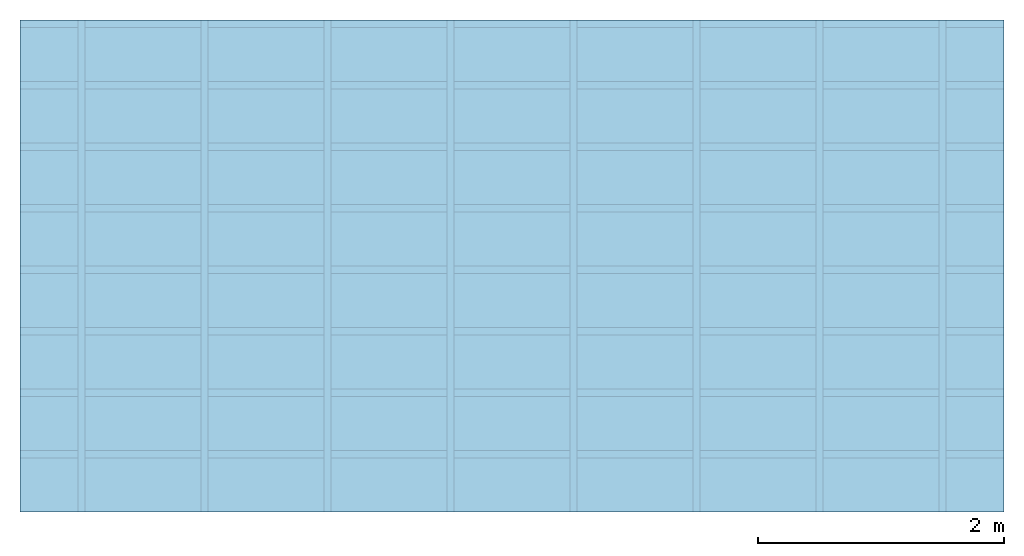
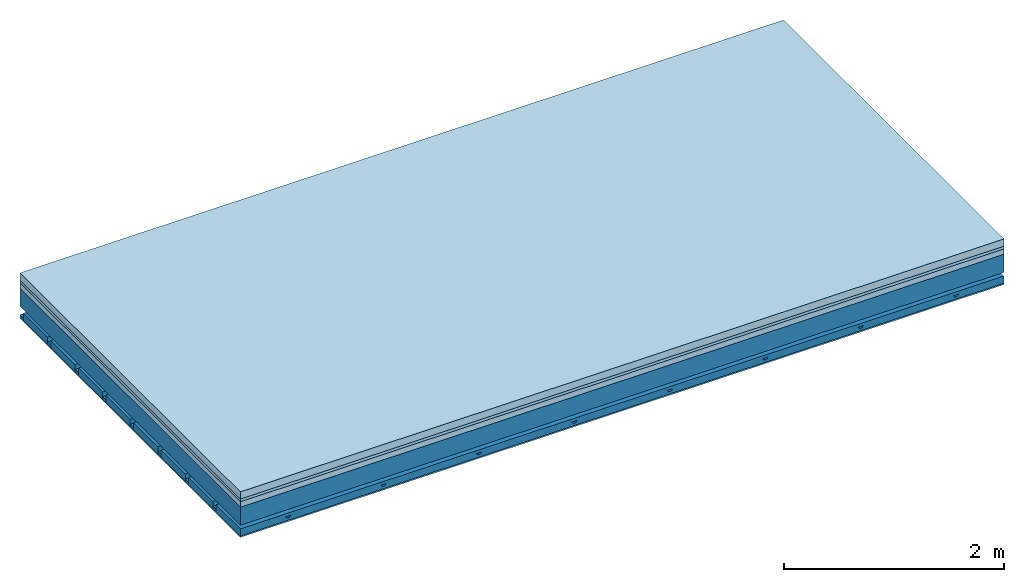
# One storey: 4 members, 4 plates, 1 element without a shape of its own.
"""IFC4 building model written with IfcOpenShell, lengths in metres."""

from ifc_helpers import new_model, si_unit, derived_unit, direction, frame, frame_2d, origin, origin_with_axes, place, context, project, spatial, polyline, rectangle, outline, extrude, material, layer, layer_set, type_object, element, aggregate, save


model = new_model("IFC4")

# Units and contexts
plan_context = context("Plan", 3, precision=1e-05, world=origin(), true_north=direction((0.0, 1.0)))
model_context = context("Model", 3, precision=1e-05, world=origin(), true_north=direction((0.0, 1.0)))
ifc_project = project(units=[si_unit("LENGTHUNIT", "METRE"), derived_unit("SOUNDPRESSUREUNIT", [(si_unit("PRESSUREUNIT", "PASCAL", prefix="MICRO"), 0)]), si_unit("ENERGYUNIT", "JOULE", prefix="MEGA"), si_unit("MASSUNIT", "GRAM", prefix="KILO"), derived_unit("THERMALTRANSMITTANCEUNIT", [(si_unit("POWERUNIT", "WATT"), 1), (si_unit("AREAUNIT", "SQUARE_METRE"), -1), (si_unit("THERMODYNAMICTEMPERATUREUNIT", "KELVIN"), -1)]), derived_unit("AREADENSITYUNIT", [(si_unit("MASSUNIT", "GRAM", prefix="KILO"), 1), (si_unit("AREAUNIT", "SQUARE_METRE"), -1)]), derived_unit("USERDEFINED", [(si_unit("ENERGYUNIT", "JOULE", prefix="MEGA"), 1), (si_unit("AREAUNIT", "SQUARE_METRE"), -1)])], contexts=[plan_context, model_context])

# Site, building, storey
site = spatial("IfcSite", under=ifc_project)
building_placement = place(None, origin())
building = spatial("IfcBuilding", under=site, at=building_placement)
storey_placement = place(building_placement, origin())
storey = spatial("IfcBuildingStorey", under=building, at=storey_placement)

# Slab, members, plates
ifc_material_1 = material(Name="Cement screed", Category="04.006")
ifc_layer_1 = layer(ifc_material_1, 0.08, Name="On-material")
ifc_material_2 = material()
ifc_layer_2 = layer(ifc_material_2, 0.03, Name="Impact sound insulation")
ifc_material_3 = material(Category="03.011")
ifc_layer_3 = layer(ifc_material_3, 0.06, Name="on Supporting structure")
ifc_layer_4 = layer(None, 0.2, Name="Supporting structure")
ifc_material_4 = material(Name="no composite action")
ifc_layer_5 = layer(ifc_material_4, 0.0, Name="Bond")
ifc_layer_6 = layer(None, 0.093, Name="Coupling")
ifc_layer_7 = layer(None, 0.027, Name="Battens / profiles")
ifc_material_5 = material(Category="03.007")
ifc_layer_8 = layer(ifc_material_5, 0.015, Name="Ceiling covering 1st layer")
ifc_material_6 = material(Name="Glued joints")
ifc_layer_9 = layer(ifc_material_6, 0.0, Name="Surface / treatment")
ifc_layer_set = layer_set([ifc_layer_1, ifc_layer_2, ifc_layer_3, ifc_layer_4, ifc_layer_5, ifc_layer_6, ifc_layer_7, ifc_layer_8, ifc_layer_9])
slab_type = type_object("IfcSlabType", Name="A1153", PredefinedType="NOTDEFINED", material=ifc_layer_set)
slab_placement = place(None, frame((0.0, 0.0, 0.0), z_axis=(0.0, 0.0, -1.0), x_axis=(1.0, 0.0, 0.0)))
slab = element("IfcSlab", 1, at=slab_placement, inside=storey, type_object=slab_type, material=ifc_layer_set, Name="Slab #1")
ifc_material_7 = material()
member_1_placement = place(slab_placement, origin())
member_1 = element("IfcMember", 2, at=member_1_placement, material=ifc_material_7, Name="Supporting structure", context=plan_context, shape_type="SweptSolid", body=[
    extrude(rectangle(XDim=1.0, YDim=0.2, at=frame_2d((0.5, 0.1), x_axis=(1.0, 0.0))), frame((0.0, 4.0, 0.17), z_axis=(0.0, -1.0, 0.0), x_axis=(1.0, 0.0, 0.0)), (0.0, 0.0, 1.0), 4.0),
    extrude(rectangle(XDim=1.0, YDim=0.2, at=frame_2d((0.5, 0.1), x_axis=(1.0, 0.0))), frame((1.0, 4.0, 0.17), z_axis=(0.0, -1.0, 0.0), x_axis=(1.0, 0.0, 0.0)), (0.0, 0.0, 1.0), 4.0),
    extrude(rectangle(XDim=1.0, YDim=0.2, at=frame_2d((0.5, 0.1), x_axis=(1.0, 0.0))), frame((2.0, 4.0, 0.17), z_axis=(0.0, -1.0, 0.0), x_axis=(1.0, 0.0, 0.0)), (0.0, 0.0, 1.0), 4.0),
    extrude(rectangle(XDim=1.0, YDim=0.2, at=frame_2d((0.5, 0.1), x_axis=(1.0, 0.0))), frame((3.0, 4.0, 0.17), z_axis=(0.0, -1.0, 0.0), x_axis=(1.0, 0.0, 0.0)), (0.0, 0.0, 1.0), 4.0),
    extrude(rectangle(XDim=1.0, YDim=0.2, at=frame_2d((0.5, 0.1), x_axis=(1.0, 0.0))), frame((4.0, 4.0, 0.17), z_axis=(0.0, -1.0, 0.0), x_axis=(1.0, 0.0, 0.0)), (0.0, 0.0, 1.0), 4.0),
    extrude(rectangle(XDim=1.0, YDim=0.2, at=frame_2d((0.5, 0.1), x_axis=(1.0, 0.0))), frame((5.0, 4.0, 0.17), z_axis=(0.0, -1.0, 0.0), x_axis=(1.0, 0.0, 0.0)), (0.0, 0.0, 1.0), 4.0),
    extrude(rectangle(XDim=1.0, YDim=0.2, at=frame_2d((0.5, 0.1), x_axis=(1.0, 0.0))), frame((6.0, 4.0, 0.17), z_axis=(0.0, -1.0, 0.0), x_axis=(1.0, 0.0, 0.0)), (0.0, 0.0, 1.0), 4.0),
    extrude(rectangle(XDim=1.0, YDim=0.2, at=frame_2d((0.5, 0.1), x_axis=(1.0, 0.0))), frame((7.0, 4.0, 0.17), z_axis=(0.0, -1.0, 0.0), x_axis=(1.0, 0.0, 0.0)), (0.0, 0.0, 1.0), 4.0),
])
ifc_material_8 = material()
member_2_placement = place(slab_placement, origin())
member_2 = element("IfcMember", 3, at=member_2_placement, material=ifc_material_8, Name="Coupling", context=plan_context, shape_type="SweptSolid", body=[
    extrude(outline(polyline([(0.0, 0.0), (0.06, 0.0), (0.04, 0.02), (0.02, 0.02), (0.0, 0.0)])), frame((0.47, 4.0, 0.443), z_axis=(0.0, -1.0, 0.0), x_axis=(1.0, 0.0, 0.0)), (0.0, 0.0, 1.0), 4.0),
    extrude(outline(polyline([(0.0, 0.0), (0.06, 0.0), (0.04, 0.02), (0.02, 0.02), (0.0, 0.0)])), frame((1.47, 4.0, 0.443), z_axis=(0.0, -1.0, 0.0), x_axis=(1.0, 0.0, 0.0)), (0.0, 0.0, 1.0), 4.0),
    extrude(outline(polyline([(0.0, 0.0), (0.06, 0.0), (0.04, 0.02), (0.02, 0.02), (0.0, 0.0)])), frame((2.47, 4.0, 0.443), z_axis=(0.0, -1.0, 0.0), x_axis=(1.0, 0.0, 0.0)), (0.0, 0.0, 1.0), 4.0),
    extrude(outline(polyline([(0.0, 0.0), (0.06, 0.0), (0.04, 0.02), (0.02, 0.02), (0.0, 0.0)])), frame((3.47, 4.0, 0.443), z_axis=(0.0, -1.0, 0.0), x_axis=(1.0, 0.0, 0.0)), (0.0, 0.0, 1.0), 4.0),
    extrude(outline(polyline([(0.0, 0.0), (0.06, 0.0), (0.04, 0.02), (0.02, 0.02), (0.0, 0.0)])), frame((4.47, 4.0, 0.443), z_axis=(0.0, -1.0, 0.0), x_axis=(1.0, 0.0, 0.0)), (0.0, 0.0, 1.0), 4.0),
    extrude(outline(polyline([(0.0, 0.0), (0.06, 0.0), (0.04, 0.02), (0.02, 0.02), (0.0, 0.0)])), frame((5.47, 4.0, 0.443), z_axis=(0.0, -1.0, 0.0), x_axis=(1.0, 0.0, 0.0)), (0.0, 0.0, 1.0), 4.0),
    extrude(outline(polyline([(0.0, 0.0), (0.06, 0.0), (0.04, 0.02), (0.02, 0.02), (0.0, 0.0)])), frame((6.47, 4.0, 0.443), z_axis=(0.0, -1.0, 0.0), x_axis=(1.0, 0.0, 0.0)), (0.0, 0.0, 1.0), 4.0),
    extrude(outline(polyline([(0.0, 0.0), (0.06, 0.0), (0.04, 0.02), (0.02, 0.02), (0.0, 0.0)])), frame((7.47, 4.0, 0.443), z_axis=(0.0, -1.0, 0.0), x_axis=(1.0, 0.0, 0.0)), (0.0, 0.0, 1.0), 4.0),
])
ifc_material_9 = material()
member_3_placement = place(slab_placement, origin())
member_3 = element("IfcMember", 4, at=member_3_placement, material=ifc_material_9, Name="Battens / profiles", context=plan_context, shape_type="SweptSolid", body=[
    extrude(rectangle(XDim=0.06, YDim=0.027, at=frame_2d((0.03, 0.0135), x_axis=(1.0, 0.0))), frame((0.0, 0.0, 0.463), z_axis=(1.0, 0.0, 0.0), x_axis=(0.0, 1.0, 0.0)), (0.0, 0.0, 1.0), 8.0),
    extrude(rectangle(XDim=0.06, YDim=0.027, at=frame_2d((0.03, 0.0135), x_axis=(1.0, 0.0))), frame((0.0, 0.5, 0.463), z_axis=(1.0, 0.0, 0.0), x_axis=(0.0, 1.0, 0.0)), (0.0, 0.0, 1.0), 8.0),
    extrude(rectangle(XDim=0.06, YDim=0.027, at=frame_2d((0.03, 0.0135), x_axis=(1.0, 0.0))), frame((0.0, 1.0, 0.463), z_axis=(1.0, 0.0, 0.0), x_axis=(0.0, 1.0, 0.0)), (0.0, 0.0, 1.0), 8.0),
    extrude(rectangle(XDim=0.06, YDim=0.027, at=frame_2d((0.03, 0.0135), x_axis=(1.0, 0.0))), frame((0.0, 1.5, 0.463), z_axis=(1.0, 0.0, 0.0), x_axis=(0.0, 1.0, 0.0)), (0.0, 0.0, 1.0), 8.0),
    extrude(rectangle(XDim=0.06, YDim=0.027, at=frame_2d((0.03, 0.0135), x_axis=(1.0, 0.0))), frame((0.0, 2.0, 0.463), z_axis=(1.0, 0.0, 0.0), x_axis=(0.0, 1.0, 0.0)), (0.0, 0.0, 1.0), 8.0),
    extrude(rectangle(XDim=0.06, YDim=0.027, at=frame_2d((0.03, 0.0135), x_axis=(1.0, 0.0))), frame((0.0, 2.5, 0.463), z_axis=(1.0, 0.0, 0.0), x_axis=(0.0, 1.0, 0.0)), (0.0, 0.0, 1.0), 8.0),
    extrude(rectangle(XDim=0.06, YDim=0.027, at=frame_2d((0.03, 0.0135), x_axis=(1.0, 0.0))), frame((0.0, 3.0, 0.463), z_axis=(1.0, 0.0, 0.0), x_axis=(0.0, 1.0, 0.0)), (0.0, 0.0, 1.0), 8.0),
    extrude(rectangle(XDim=0.06, YDim=0.027, at=frame_2d((0.03, 0.0135), x_axis=(1.0, 0.0))), frame((0.0, 3.5, 0.463), z_axis=(1.0, 0.0, 0.0), x_axis=(0.0, 1.0, 0.0)), (0.0, 0.0, 1.0), 8.0),
])
ifc_material_10 = material()
member_4_placement = place(slab_placement, origin())
member_4 = element("IfcMember", 5, at=member_4_placement, material=ifc_material_10, Name="Cavity", context=plan_context, shape_type="SweptSolid", body=[
    extrude(rectangle(XDim=0.44, YDim=0.08, at=frame_2d((0.22, 0.04), x_axis=(1.0, 0.0))), frame((0.0, 0.06, 0.41), z_axis=(1.0, 0.0, 0.0), x_axis=(0.0, 1.0, 0.0)), (0.0, 0.0, 1.0), 8.0),
    extrude(rectangle(XDim=0.44, YDim=0.08, at=frame_2d((0.22, 0.04), x_axis=(1.0, 0.0))), frame((0.0, 0.56, 0.41), z_axis=(1.0, 0.0, 0.0), x_axis=(0.0, 1.0, 0.0)), (0.0, 0.0, 1.0), 8.0),
    extrude(rectangle(XDim=0.44, YDim=0.08, at=frame_2d((0.22, 0.04), x_axis=(1.0, 0.0))), frame((0.0, 1.06, 0.41), z_axis=(1.0, 0.0, 0.0), x_axis=(0.0, 1.0, 0.0)), (0.0, 0.0, 1.0), 8.0),
    extrude(rectangle(XDim=0.44, YDim=0.08, at=frame_2d((0.22, 0.04), x_axis=(1.0, 0.0))), frame((0.0, 1.56, 0.41), z_axis=(1.0, 0.0, 0.0), x_axis=(0.0, 1.0, 0.0)), (0.0, 0.0, 1.0), 8.0),
    extrude(rectangle(XDim=0.44, YDim=0.08, at=frame_2d((0.22, 0.04), x_axis=(1.0, 0.0))), frame((0.0, 2.06, 0.41), z_axis=(1.0, 0.0, 0.0), x_axis=(0.0, 1.0, 0.0)), (0.0, 0.0, 1.0), 8.0),
    extrude(rectangle(XDim=0.44, YDim=0.08, at=frame_2d((0.22, 0.04), x_axis=(1.0, 0.0))), frame((0.0, 2.56, 0.41), z_axis=(1.0, 0.0, 0.0), x_axis=(0.0, 1.0, 0.0)), (0.0, 0.0, 1.0), 8.0),
    extrude(rectangle(XDim=0.44, YDim=0.08, at=frame_2d((0.22, 0.04), x_axis=(1.0, 0.0))), frame((0.0, 3.06, 0.41), z_axis=(1.0, 0.0, 0.0), x_axis=(0.0, 1.0, 0.0)), (0.0, 0.0, 1.0), 8.0),
    extrude(rectangle(XDim=0.44, YDim=0.08, at=frame_2d((0.22, 0.04), x_axis=(1.0, 0.0))), frame((0.0, 3.56, 0.41), z_axis=(1.0, 0.0, 0.0), x_axis=(0.0, 1.0, 0.0)), (0.0, 0.0, 1.0), 8.0),
])
plate_1_placement = place(slab_placement, origin())
plate_1 = element("IfcPlate", 6, at=plate_1_placement, material=ifc_material_1, Name="On-material", context=plan_context, shape_type="SweptSolid", body=[
    extrude(rectangle(XDim=8.0, YDim=4.0, at=frame_2d((4.0, 2.0), x_axis=(1.0, 0.0))), origin_with_axes(), (0.0, 0.0, 1.0), 0.08),
])
plate_2_placement = place(slab_placement, origin())
plate_2 = element("IfcPlate", 7, at=plate_2_placement, material=ifc_material_2, Name="Impact sound insulation", context=plan_context, shape_type="SweptSolid", body=[
    extrude(rectangle(XDim=8.0, YDim=4.0, at=frame_2d((4.0, 2.0), x_axis=(1.0, 0.0))), frame((0.0, 0.0, 0.08), z_axis=(0.0, 0.0, 1.0), x_axis=(1.0, 0.0, 0.0)), (0.0, 0.0, 1.0), 0.03),
])
plate_3_placement = place(slab_placement, origin())
plate_3 = element("IfcPlate", 8, at=plate_3_placement, material=ifc_material_3, Name="on Supporting structure", context=plan_context, shape_type="SweptSolid", body=[
    extrude(rectangle(XDim=8.0, YDim=4.0, at=frame_2d((4.0, 2.0), x_axis=(1.0, 0.0))), frame((0.0, 0.0, 0.11), z_axis=(0.0, 0.0, 1.0), x_axis=(1.0, 0.0, 0.0)), (0.0, 0.0, 1.0), 0.06),
])
plate_4_placement = place(slab_placement, origin())
plate_4 = element("IfcPlate", 9, at=plate_4_placement, material=ifc_material_5, Name="Ceiling covering 1st layer", context=plan_context, shape_type="SweptSolid", body=[
    extrude(rectangle(XDim=8.0, YDim=4.0, at=frame_2d((4.0, 2.0), x_axis=(1.0, 0.0))), frame((0.0, 0.0, 0.49), z_axis=(0.0, 0.0, 1.0), x_axis=(1.0, 0.0, 0.0)), (0.0, 0.0, 1.0), 0.015),
])
aggregate(slab, [plate_1, plate_2, plate_3, member_1, member_2, member_3, member_4, plate_4])

save(model, "model.ifc")
